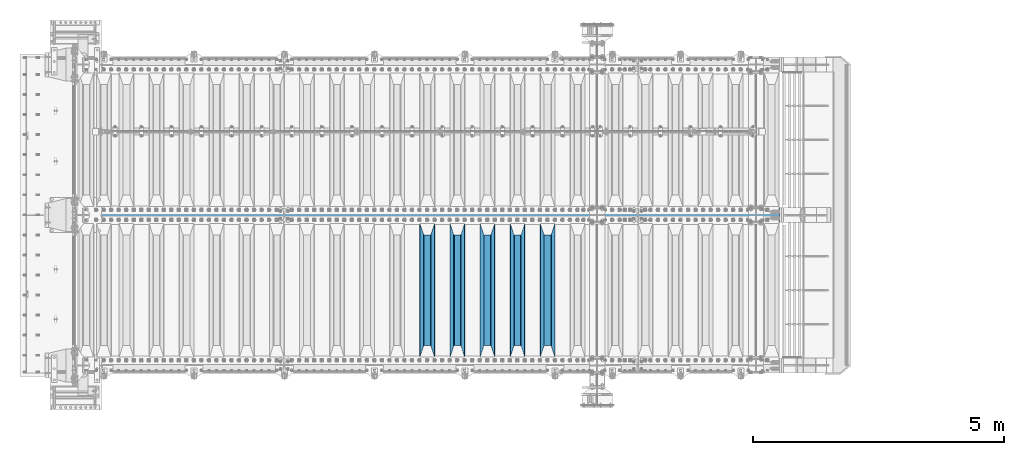
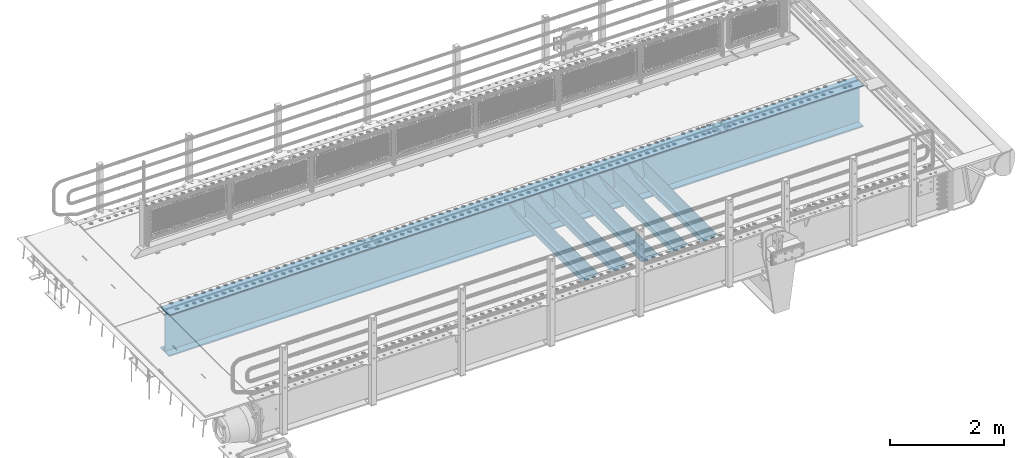
# One storey, part 94 of 193: 6 beams.
"""IFC2X3 building model written with IfcOpenShell, lengths in millimetres."""

from ifc_helpers import new_model, si_unit, frame, origin_with_axes, place, context, subcontext, project, spatial, faceted_brep, material, type_object, element, save


model = new_model("IFC2X3")

# Units and contexts
model_context = context("Model", 3, precision=1e-05, world=origin_with_axes())
body_context = subcontext(model_context, "Body", "Model", "MODEL_VIEW")
ifc_project = project(units=[si_unit("LENGTHUNIT", "METRE", prefix="MILLI"), si_unit("AREAUNIT", "SQUARE_METRE"), si_unit("VOLUMEUNIT", "CUBIC_METRE"), si_unit("MASSUNIT", "GRAM", prefix="KILO"), si_unit("TIMEUNIT", "SECOND"), si_unit("PLANEANGLEUNIT", "RADIAN"), si_unit("SOLIDANGLEUNIT", "STERADIAN"), si_unit("THERMODYNAMICTEMPERATUREUNIT", "DEGREE_CELSIUS"), si_unit("LUMINOUSINTENSITYUNIT", "LUMEN")], contexts=[model_context])

# Site, building, storey
site_placement = place(None, origin_with_axes())
site = spatial("IfcSite", under=ifc_project, at=site_placement, CompositionType="ELEMENT")
building_placement = place(site_placement, origin_with_axes())
building = spatial("IfcBuilding", under=site, at=building_placement, Name="Standard", CompositionType="ELEMENT")
storey_placement = place(building_placement, origin_with_axes())
storey = spatial("IfcBuildingStorey", under=building, at=storey_placement, Name="Undefined", CompositionType="ELEMENT", Elevation=0.0)

# Beams
ifc_material = material(Name="STEEL/S355N")
beam_type_1 = type_object("IfcBeamType", PredefinedType="NOTDEFINED")
beam_1_placement = place(storey_placement, frame((-33050.0, 24175.0, -115.0), z_axis=(0.0, 0.0, 1.0), x_axis=(0.0, 1.0, 0.0)))
element("IfcBeam", 1, at=beam_1_placement, inside=storey, type_object=beam_type_1, material=ifc_material, context=body_context, shape_type="Brep", body=[
    faceted_brep([(0.0, 150.0, 115.0), (0.0, 143.689999999999, 115.0), (2650.00000000297, 143.689999999999, 115.0), (2650.00000000297, 150.0, 115.0), (2650.00000000297, 142.059565218398, 110.000000003094), (2650.00000000297, 148.3695652184, 110.000000003094), (2441.90079219209, -80.1103600731112, -98.0992078077845), (2437.7588105432, -77.5672621345584, -102.241189456673), (2434.06523489747, -74.4080125315522, -105.934765102404), (2430.9108609509, -70.710272125576, -109.089139048974), (2428.37322971128, -66.5649389910068, -111.626770288588), (2426.51472138055, -62.0739139532889, -113.485278619323), (2425.38102192092, -57.3475956567672, -114.618978078955), (2424.99999999988, -52.5021667386536, -115.0), (2424.99999999988, 52.5021667386536, -115.0), (2425.38102192092, 57.3475956567672, -114.618978078955), (2426.51472138055, 62.0739139532889, -113.485278619323), (2428.37322971128, 66.5649389910068, -111.626770288588), (2430.9108609509, 70.710272125576, -109.089139048974), (2434.06523489747, 74.4080125315522, -105.934765102404), (2437.7588105432, 77.5672621345584, -102.241189456673), (2441.90079219209, 80.1103600731112, -98.0992078077846), (2446.38936140512, 81.9747917625791, -93.6106385947584), (2448.2494850041, 76.2713538057251, -91.7505149957729), (2444.62967112263, 74.76777986261, -95.3703288772456), (2441.28936334127, 72.7168944282894, -98.710636658607), (2438.31067330439, 70.1691124903846, -101.689326695487), (2435.76682334748, 67.1870637758839, -104.233176652398), (2433.72034654134, 63.8440531834895, -106.279653458539), (2432.22154950042, 60.222258798236, -107.778450499454), (2431.30727574265, 56.4107117849089, -108.692724257221), (2430.99999999987, 52.5031078186876, -109.0), (2430.99999999987, -52.5031078186876, -109.0), (2431.30727574265, -56.4107117849089, -108.692724257221), (2432.22154950042, -60.222258798236, -107.778450499454), (2433.72034654134, -63.8440531834895, -106.279653458539), (2435.76682334748, -67.1870637758839, -104.233176652398), (2438.31067330439, -70.1691124903846, -101.689326695487), (2441.28936334127, -72.7168944282894, -98.7106366586071), (2444.62967112263, -74.76777986261, -95.3703288772457), (2448.2494850041, -76.2713538057251, -91.7505149957729), (2650.00000000297, -142.059565218398, 110.000000003094), (2650.00000000297, -148.3695652184, 110.000000003094), (2446.38936140512, -81.9747917625791, -93.6106385947584), (2650.00000000297, -143.689999999999, 115.0), (2650.00000000297, -150.0, 115.0), (0.0, -143.689999999999, 115.0), (0.0, -150.0, 115.0), (0.0, -148.369565218261, 110.000000002667), (203.610638597427, -81.9747917625791, -93.6106385947584), (208.099207810446, -80.1103600731112, -98.0992078077845), (212.241189459342, -77.5672621345584, -102.241189456673), (215.93476510507, -74.4080125315522, -105.934765102404), (219.089139051641, -70.710272125576, -109.089139048974), (221.626770291256, -66.5649389910068, -111.626770288588), (223.485278621989, -62.0739139532889, -113.485278619323), (224.618978081624, -57.3475956567672, -114.618978078955), (225.000000002663, -52.5021667386536, -115.0), (225.000000002663, 52.5021667386536, -115.0), (224.618978081624, 57.3475956567672, -114.618978078955), (223.485278621989, 62.0739139532889, -113.485278619323), (221.626770291256, 66.5649389910068, -111.626770288588), (219.089139051641, 70.710272125576, -109.089139048974), (215.93476510507, 74.4080125315522, -105.934765102404), (212.241189459342, 77.5672621345584, -102.241189456673), (208.099207810446, 80.1103600731112, -98.0992078077846), (203.610638597427, 81.9747917625791, -93.6106385947584), (0.0, 148.369565218261, 110.000000002667), (0.0, 142.05956521826, 110.000000002667), (201.750514998439, 76.2713538057251, -91.7505149957729), (205.370328879915, 74.76777986261, -95.3703288772456), (208.710636661275, 72.7168944282894, -98.710636658607), (211.689326698157, 70.1691124903846, -101.689326695487), (214.233176655063, 67.1870637758839, -104.233176652398), (216.279653461206, 63.8440531834895, -106.279653458539), (217.778450502123, 60.222258798236, -107.778450499454), (218.69272425989, 56.4107117849089, -108.692724257221), (219.00000000267, 52.5031078186876, -109.0), (219.00000000267, -52.5031078186876, -109.0), (218.69272425989, -56.4107117849089, -108.692724257221), (217.778450502123, -60.222258798236, -107.778450499454), (216.279653461206, -63.8440531834895, -106.279653458539), (214.233176655063, -67.1870637758839, -104.233176652398), (211.689326698157, -70.1691124903846, -101.689326695487), (208.710636661275, -72.7168944282894, -98.7106366586071), (205.370328879915, -74.76777986261, -95.3703288772457), (201.750514998439, -76.2713538057251, -91.7505149957729), (0.0, -142.05956521826, 110.000000002667)], [[[0, 1, 2, 3]], [[3, 2, 4, 5]], [[6, 7, 8, 9, 10, 11, 12, 13, 14, 15, 16, 17, 18, 19, 20, 21, 22, 5, 4, 23, 24, 25, 26, 27, 28, 29, 30, 31, 32, 33, 34, 35, 36, 37, 38, 39, 40, 41, 42, 43]], [[44, 45, 42, 41]], [[46, 47, 45, 44]], [[43, 42, 45, 47, 48, 49]], [[6, 43, 49, 50]], [[7, 6, 50, 51]], [[8, 7, 51, 52]], [[9, 8, 52, 53]], [[10, 9, 53, 54]], [[11, 10, 54, 55]], [[12, 11, 55, 56]], [[13, 12, 56, 57]], [[14, 13, 57, 58]], [[15, 14, 58, 59]], [[16, 15, 59, 60]], [[17, 16, 60, 61]], [[18, 17, 61, 62]], [[19, 18, 62, 63]], [[20, 19, 63, 64]], [[21, 20, 64, 65]], [[22, 21, 65, 66]], [[0, 3, 5, 22, 66, 67]], [[1, 0, 67, 68]], [[23, 4, 2, 1, 68, 69]], [[24, 23, 69, 70]], [[25, 24, 70, 71]], [[26, 25, 71, 72]], [[27, 26, 72, 73]], [[28, 27, 73, 74]], [[29, 28, 74, 75]], [[30, 29, 75, 76]], [[31, 30, 76, 77]], [[32, 31, 77, 78]], [[33, 32, 78, 79]], [[34, 33, 79, 80]], [[35, 34, 80, 81]], [[36, 35, 81, 82]], [[37, 36, 82, 83]], [[38, 37, 83, 84]], [[39, 38, 84, 85]], [[40, 39, 85, 86]], [[46, 44, 41, 40, 86, 87]], [[47, 46, 87, 48]], [[86, 85, 84, 83, 82, 81, 80, 79, 78, 77, 76, 75, 74, 73, 72, 71, 70, 69, 68, 67, 66, 65, 64, 63, 62, 61, 60, 59, 58, 57, 56, 55, 54, 53, 52, 51, 50, 49, 48, 87]]]),
])
beam_2_placement = place(storey_placement, frame((-33650.0, 24175.0, -115.0), z_axis=(0.0, 0.0, 1.0), x_axis=(0.0, 1.0, 0.0)))
element("IfcBeam", 2, at=beam_2_placement, inside=storey, type_object=beam_type_1, material=ifc_material, context=body_context, shape_type="Brep", body=[
    faceted_brep([(0.0, 150.0, 115.0), (0.0, 143.689999999999, 115.0), (2650.00000000297, 143.689999999999, 115.0), (2650.00000000297, 150.0, 115.0), (2650.00000000297, 142.059565218398, 110.000000003094), (2650.00000000297, 148.3695652184, 110.000000003094), (2441.90079219209, -80.1103600731112, -98.0992078077845), (2437.7588105432, -77.5672621345584, -102.241189456673), (2434.06523489747, -74.4080125315522, -105.934765102404), (2430.9108609509, -70.710272125576, -109.089139048974), (2428.37322971128, -66.5649389910068, -111.626770288588), (2426.51472138055, -62.0739139532889, -113.485278619323), (2425.38102192092, -57.3475956567672, -114.618978078955), (2424.99999999988, -52.5021667386536, -115.0), (2424.99999999988, 52.5021667386536, -115.0), (2425.38102192092, 57.3475956567672, -114.618978078955), (2426.51472138055, 62.0739139532889, -113.485278619323), (2428.37322971128, 66.5649389910068, -111.626770288588), (2430.9108609509, 70.710272125576, -109.089139048974), (2434.06523489747, 74.4080125315522, -105.934765102404), (2437.7588105432, 77.5672621345584, -102.241189456673), (2441.90079219209, 80.1103600731112, -98.0992078077846), (2446.38936140512, 81.9747917625791, -93.6106385947584), (2448.2494850041, 76.2713538057251, -91.7505149957729), (2444.62967112263, 74.76777986261, -95.3703288772456), (2441.28936334127, 72.7168944282894, -98.710636658607), (2438.31067330439, 70.1691124903846, -101.689326695487), (2435.76682334748, 67.1870637758839, -104.233176652398), (2433.72034654134, 63.8440531834895, -106.279653458539), (2432.22154950042, 60.222258798236, -107.778450499454), (2431.30727574265, 56.4107117849089, -108.692724257221), (2430.99999999987, 52.5031078186876, -109.0), (2430.99999999987, -52.5031078186876, -109.0), (2431.30727574265, -56.4107117849089, -108.692724257221), (2432.22154950042, -60.222258798236, -107.778450499454), (2433.72034654134, -63.8440531834895, -106.279653458539), (2435.76682334748, -67.1870637758839, -104.233176652398), (2438.31067330439, -70.1691124903846, -101.689326695487), (2441.28936334127, -72.7168944282894, -98.7106366586071), (2444.62967112263, -74.76777986261, -95.3703288772457), (2448.2494850041, -76.2713538057251, -91.7505149957729), (2650.00000000297, -142.059565218398, 110.000000003094), (2650.00000000297, -148.3695652184, 110.000000003094), (2446.38936140512, -81.9747917625791, -93.6106385947584), (2650.00000000297, -143.689999999999, 115.0), (2650.00000000297, -150.0, 115.0), (0.0, -143.689999999999, 115.0), (0.0, -150.0, 115.0), (0.0, -148.369565218261, 110.000000002667), (203.610638597427, -81.9747917625791, -93.6106385947584), (208.099207810446, -80.1103600731112, -98.0992078077845), (212.241189459342, -77.5672621345584, -102.241189456673), (215.93476510507, -74.4080125315522, -105.934765102404), (219.089139051641, -70.710272125576, -109.089139048974), (221.626770291256, -66.5649389910068, -111.626770288588), (223.485278621989, -62.0739139532889, -113.485278619323), (224.618978081624, -57.3475956567672, -114.618978078955), (225.000000002663, -52.5021667386536, -115.0), (225.000000002663, 52.5021667386536, -115.0), (224.618978081624, 57.3475956567672, -114.618978078955), (223.485278621989, 62.0739139532889, -113.485278619323), (221.626770291256, 66.5649389910068, -111.626770288588), (219.089139051641, 70.710272125576, -109.089139048974), (215.93476510507, 74.4080125315522, -105.934765102404), (212.241189459342, 77.5672621345584, -102.241189456673), (208.099207810446, 80.1103600731112, -98.0992078077846), (203.610638597427, 81.9747917625791, -93.6106385947584), (0.0, 148.369565218261, 110.000000002667), (0.0, 142.05956521826, 110.000000002667), (201.750514998439, 76.2713538057251, -91.7505149957729), (205.370328879915, 74.76777986261, -95.3703288772456), (208.710636661275, 72.7168944282894, -98.710636658607), (211.689326698157, 70.1691124903846, -101.689326695487), (214.233176655063, 67.1870637758839, -104.233176652398), (216.279653461206, 63.8440531834895, -106.279653458539), (217.778450502123, 60.222258798236, -107.778450499454), (218.69272425989, 56.4107117849089, -108.692724257221), (219.00000000267, 52.5031078186876, -109.0), (219.00000000267, -52.5031078186876, -109.0), (218.69272425989, -56.4107117849089, -108.692724257221), (217.778450502123, -60.222258798236, -107.778450499454), (216.279653461206, -63.8440531834895, -106.279653458539), (214.233176655063, -67.1870637758839, -104.233176652398), (211.689326698157, -70.1691124903846, -101.689326695487), (208.710636661275, -72.7168944282894, -98.7106366586071), (205.370328879915, -74.76777986261, -95.3703288772457), (201.750514998439, -76.2713538057251, -91.7505149957729), (0.0, -142.05956521826, 110.000000002667)], [[[0, 1, 2, 3]], [[3, 2, 4, 5]], [[6, 7, 8, 9, 10, 11, 12, 13, 14, 15, 16, 17, 18, 19, 20, 21, 22, 5, 4, 23, 24, 25, 26, 27, 28, 29, 30, 31, 32, 33, 34, 35, 36, 37, 38, 39, 40, 41, 42, 43]], [[44, 45, 42, 41]], [[46, 47, 45, 44]], [[43, 42, 45, 47, 48, 49]], [[6, 43, 49, 50]], [[7, 6, 50, 51]], [[8, 7, 51, 52]], [[9, 8, 52, 53]], [[10, 9, 53, 54]], [[11, 10, 54, 55]], [[12, 11, 55, 56]], [[13, 12, 56, 57]], [[14, 13, 57, 58]], [[15, 14, 58, 59]], [[16, 15, 59, 60]], [[17, 16, 60, 61]], [[18, 17, 61, 62]], [[19, 18, 62, 63]], [[20, 19, 63, 64]], [[21, 20, 64, 65]], [[22, 21, 65, 66]], [[0, 3, 5, 22, 66, 67]], [[1, 0, 67, 68]], [[23, 4, 2, 1, 68, 69]], [[24, 23, 69, 70]], [[25, 24, 70, 71]], [[26, 25, 71, 72]], [[27, 26, 72, 73]], [[28, 27, 73, 74]], [[29, 28, 74, 75]], [[30, 29, 75, 76]], [[31, 30, 76, 77]], [[32, 31, 77, 78]], [[33, 32, 78, 79]], [[34, 33, 79, 80]], [[35, 34, 80, 81]], [[36, 35, 81, 82]], [[37, 36, 82, 83]], [[38, 37, 83, 84]], [[39, 38, 84, 85]], [[40, 39, 85, 86]], [[46, 44, 41, 40, 86, 87]], [[47, 46, 87, 48]], [[86, 85, 84, 83, 82, 81, 80, 79, 78, 77, 76, 75, 74, 73, 72, 71, 70, 69, 68, 67, 66, 65, 64, 63, 62, 61, 60, 59, 58, 57, 56, 55, 54, 53, 52, 51, 50, 49, 48, 87]]]),
])
beam_3_placement = place(storey_placement, frame((-34250.0, 24175.0, -115.0), z_axis=(0.0, 0.0, 1.0), x_axis=(0.0, 1.0, 0.0)))
element("IfcBeam", 3, at=beam_3_placement, inside=storey, type_object=beam_type_1, material=ifc_material, context=body_context, shape_type="Brep", body=[
    faceted_brep([(0.0, 150.0, 115.0), (0.0, 143.689999999999, 115.0), (2650.00000000297, 143.689999999999, 115.0), (2650.00000000297, 150.0, 115.0), (2650.00000000297, 142.059565218398, 110.000000003094), (2650.00000000297, 148.3695652184, 110.000000003094), (2441.90079219209, -80.1103600731112, -98.0992078077845), (2437.7588105432, -77.5672621345584, -102.241189456673), (2434.06523489747, -74.4080125315522, -105.934765102404), (2430.9108609509, -70.710272125576, -109.089139048974), (2428.37322971128, -66.5649389910068, -111.626770288588), (2426.51472138055, -62.0739139532889, -113.485278619323), (2425.38102192092, -57.3475956567672, -114.618978078955), (2424.99999999988, -52.5021667386536, -115.0), (2424.99999999988, 52.5021667386536, -115.0), (2425.38102192092, 57.3475956567672, -114.618978078955), (2426.51472138055, 62.0739139532889, -113.485278619323), (2428.37322971128, 66.5649389910068, -111.626770288588), (2430.9108609509, 70.710272125576, -109.089139048974), (2434.06523489747, 74.4080125315522, -105.934765102404), (2437.7588105432, 77.5672621345584, -102.241189456673), (2441.90079219209, 80.1103600731112, -98.0992078077846), (2446.38936140512, 81.9747917625791, -93.6106385947584), (2448.2494850041, 76.2713538057251, -91.7505149957729), (2444.62967112263, 74.76777986261, -95.3703288772456), (2441.28936334127, 72.7168944282894, -98.710636658607), (2438.31067330439, 70.1691124903846, -101.689326695487), (2435.76682334748, 67.1870637758839, -104.233176652398), (2433.72034654134, 63.8440531834895, -106.279653458539), (2432.22154950042, 60.222258798236, -107.778450499454), (2431.30727574265, 56.4107117849089, -108.692724257221), (2430.99999999987, 52.5031078186876, -109.0), (2430.99999999987, -52.5031078186876, -109.0), (2431.30727574265, -56.4107117849089, -108.692724257221), (2432.22154950042, -60.222258798236, -107.778450499454), (2433.72034654134, -63.8440531834895, -106.279653458539), (2435.76682334748, -67.1870637758839, -104.233176652398), (2438.31067330439, -70.1691124903846, -101.689326695487), (2441.28936334127, -72.7168944282894, -98.7106366586071), (2444.62967112263, -74.76777986261, -95.3703288772457), (2448.2494850041, -76.2713538057251, -91.7505149957729), (2650.00000000297, -142.059565218398, 110.000000003094), (2650.00000000297, -148.3695652184, 110.000000003094), (2446.38936140512, -81.9747917625791, -93.6106385947584), (2650.00000000297, -143.689999999999, 115.0), (2650.00000000297, -150.0, 115.0), (0.0, -143.689999999999, 115.0), (0.0, -150.0, 115.0), (0.0, -148.369565218261, 110.000000002667), (203.610638597427, -81.9747917625791, -93.6106385947584), (208.099207810446, -80.1103600731112, -98.0992078077845), (212.241189459342, -77.5672621345584, -102.241189456673), (215.93476510507, -74.4080125315522, -105.934765102404), (219.089139051641, -70.710272125576, -109.089139048974), (221.626770291256, -66.5649389910068, -111.626770288588), (223.485278621989, -62.0739139532889, -113.485278619323), (224.618978081624, -57.3475956567672, -114.618978078955), (225.000000002663, -52.5021667386536, -115.0), (225.000000002663, 52.5021667386536, -115.0), (224.618978081624, 57.3475956567672, -114.618978078955), (223.485278621989, 62.0739139532889, -113.485278619323), (221.626770291256, 66.5649389910068, -111.626770288588), (219.089139051641, 70.710272125576, -109.089139048974), (215.93476510507, 74.4080125315522, -105.934765102404), (212.241189459342, 77.5672621345584, -102.241189456673), (208.099207810446, 80.1103600731112, -98.0992078077846), (203.610638597427, 81.9747917625791, -93.6106385947584), (0.0, 148.369565218261, 110.000000002667), (0.0, 142.05956521826, 110.000000002667), (201.750514998439, 76.2713538057251, -91.7505149957729), (205.370328879915, 74.76777986261, -95.3703288772456), (208.710636661275, 72.7168944282894, -98.710636658607), (211.689326698157, 70.1691124903846, -101.689326695487), (214.233176655063, 67.1870637758839, -104.233176652398), (216.279653461206, 63.8440531834895, -106.279653458539), (217.778450502123, 60.222258798236, -107.778450499454), (218.69272425989, 56.4107117849089, -108.692724257221), (219.00000000267, 52.5031078186876, -109.0), (219.00000000267, -52.5031078186876, -109.0), (218.69272425989, -56.4107117849089, -108.692724257221), (217.778450502123, -60.222258798236, -107.778450499454), (216.279653461206, -63.8440531834895, -106.279653458539), (214.233176655063, -67.1870637758839, -104.233176652398), (211.689326698157, -70.1691124903846, -101.689326695487), (208.710636661275, -72.7168944282894, -98.7106366586071), (205.370328879915, -74.76777986261, -95.3703288772457), (201.750514998439, -76.2713538057251, -91.7505149957729), (0.0, -142.05956521826, 110.000000002667)], [[[0, 1, 2, 3]], [[3, 2, 4, 5]], [[6, 7, 8, 9, 10, 11, 12, 13, 14, 15, 16, 17, 18, 19, 20, 21, 22, 5, 4, 23, 24, 25, 26, 27, 28, 29, 30, 31, 32, 33, 34, 35, 36, 37, 38, 39, 40, 41, 42, 43]], [[44, 45, 42, 41]], [[46, 47, 45, 44]], [[43, 42, 45, 47, 48, 49]], [[6, 43, 49, 50]], [[7, 6, 50, 51]], [[8, 7, 51, 52]], [[9, 8, 52, 53]], [[10, 9, 53, 54]], [[11, 10, 54, 55]], [[12, 11, 55, 56]], [[13, 12, 56, 57]], [[14, 13, 57, 58]], [[15, 14, 58, 59]], [[16, 15, 59, 60]], [[17, 16, 60, 61]], [[18, 17, 61, 62]], [[19, 18, 62, 63]], [[20, 19, 63, 64]], [[21, 20, 64, 65]], [[22, 21, 65, 66]], [[0, 3, 5, 22, 66, 67]], [[1, 0, 67, 68]], [[23, 4, 2, 1, 68, 69]], [[24, 23, 69, 70]], [[25, 24, 70, 71]], [[26, 25, 71, 72]], [[27, 26, 72, 73]], [[28, 27, 73, 74]], [[29, 28, 74, 75]], [[30, 29, 75, 76]], [[31, 30, 76, 77]], [[32, 31, 77, 78]], [[33, 32, 78, 79]], [[34, 33, 79, 80]], [[35, 34, 80, 81]], [[36, 35, 81, 82]], [[37, 36, 82, 83]], [[38, 37, 83, 84]], [[39, 38, 84, 85]], [[40, 39, 85, 86]], [[46, 44, 41, 40, 86, 87]], [[47, 46, 87, 48]], [[86, 85, 84, 83, 82, 81, 80, 79, 78, 77, 76, 75, 74, 73, 72, 71, 70, 69, 68, 67, 66, 65, 64, 63, 62, 61, 60, 59, 58, 57, 56, 55, 54, 53, 52, 51, 50, 49, 48, 87]]]),
])
beam_4_placement = place(storey_placement, frame((-34850.0, 24175.0, -115.0), z_axis=(0.0, 0.0, 1.0), x_axis=(0.0, 1.0, 0.0)))
element("IfcBeam", 4, at=beam_4_placement, inside=storey, type_object=beam_type_1, material=ifc_material, context=body_context, shape_type="Brep", body=[
    faceted_brep([(0.0, 150.0, 115.0), (0.0, 143.689999999999, 115.0), (2650.00000000297, 143.689999999999, 115.0), (2650.00000000297, 150.0, 115.0), (2650.00000000297, 142.059565218398, 110.000000003094), (2650.00000000297, 148.3695652184, 110.000000003094), (2441.90079219209, -80.1103600731112, -98.0992078077845), (2437.7588105432, -77.5672621345584, -102.241189456673), (2434.06523489747, -74.4080125315522, -105.934765102404), (2430.9108609509, -70.710272125576, -109.089139048974), (2428.37322971128, -66.5649389910068, -111.626770288588), (2426.51472138055, -62.0739139532889, -113.485278619323), (2425.38102192092, -57.3475956567672, -114.618978078955), (2424.99999999988, -52.5021667386536, -115.0), (2424.99999999988, 52.5021667386536, -115.0), (2425.38102192092, 57.3475956567672, -114.618978078955), (2426.51472138055, 62.0739139532889, -113.485278619323), (2428.37322971128, 66.5649389910068, -111.626770288588), (2430.9108609509, 70.710272125576, -109.089139048974), (2434.06523489747, 74.4080125315522, -105.934765102404), (2437.7588105432, 77.5672621345584, -102.241189456673), (2441.90079219209, 80.1103600731112, -98.0992078077846), (2446.38936140512, 81.9747917625791, -93.6106385947584), (2448.2494850041, 76.2713538057251, -91.7505149957729), (2444.62967112263, 74.76777986261, -95.3703288772456), (2441.28936334127, 72.7168944282894, -98.710636658607), (2438.31067330439, 70.1691124903846, -101.689326695487), (2435.76682334748, 67.1870637758839, -104.233176652398), (2433.72034654134, 63.8440531834895, -106.279653458539), (2432.22154950042, 60.222258798236, -107.778450499454), (2431.30727574265, 56.4107117849089, -108.692724257221), (2430.99999999987, 52.5031078186876, -109.0), (2430.99999999987, -52.5031078186876, -109.0), (2431.30727574265, -56.4107117849089, -108.692724257221), (2432.22154950042, -60.222258798236, -107.778450499454), (2433.72034654134, -63.8440531834895, -106.279653458539), (2435.76682334748, -67.1870637758839, -104.233176652398), (2438.31067330439, -70.1691124903846, -101.689326695487), (2441.28936334127, -72.7168944282894, -98.7106366586071), (2444.62967112263, -74.76777986261, -95.3703288772457), (2448.2494850041, -76.2713538057251, -91.7505149957729), (2650.00000000297, -142.059565218398, 110.000000003094), (2650.00000000297, -148.3695652184, 110.000000003094), (2446.38936140512, -81.9747917625791, -93.6106385947584), (2650.00000000297, -143.689999999999, 115.0), (2650.00000000297, -150.0, 115.0), (0.0, -143.689999999999, 115.0), (0.0, -150.0, 115.0), (0.0, -148.369565218261, 110.000000002667), (203.610638597427, -81.9747917625791, -93.6106385947584), (208.099207810446, -80.1103600731112, -98.0992078077845), (212.241189459342, -77.5672621345584, -102.241189456673), (215.93476510507, -74.4080125315522, -105.934765102404), (219.089139051641, -70.710272125576, -109.089139048974), (221.626770291256, -66.5649389910068, -111.626770288588), (223.485278621989, -62.0739139532889, -113.485278619323), (224.618978081624, -57.3475956567672, -114.618978078955), (225.000000002663, -52.5021667386536, -115.0), (225.000000002663, 52.5021667386536, -115.0), (224.618978081624, 57.3475956567672, -114.618978078955), (223.485278621989, 62.0739139532889, -113.485278619323), (221.626770291256, 66.5649389910068, -111.626770288588), (219.089139051641, 70.710272125576, -109.089139048974), (215.93476510507, 74.4080125315522, -105.934765102404), (212.241189459342, 77.5672621345584, -102.241189456673), (208.099207810446, 80.1103600731112, -98.0992078077846), (203.610638597427, 81.9747917625791, -93.6106385947584), (0.0, 148.369565218261, 110.000000002667), (0.0, 142.05956521826, 110.000000002667), (201.750514998439, 76.2713538057251, -91.7505149957729), (205.370328879915, 74.76777986261, -95.3703288772456), (208.710636661275, 72.7168944282894, -98.710636658607), (211.689326698157, 70.1691124903846, -101.689326695487), (214.233176655063, 67.1870637758839, -104.233176652398), (216.279653461206, 63.8440531834895, -106.279653458539), (217.778450502123, 60.222258798236, -107.778450499454), (218.69272425989, 56.4107117849089, -108.692724257221), (219.00000000267, 52.5031078186876, -109.0), (219.00000000267, -52.5031078186876, -109.0), (218.69272425989, -56.4107117849089, -108.692724257221), (217.778450502123, -60.222258798236, -107.778450499454), (216.279653461206, -63.8440531834895, -106.279653458539), (214.233176655063, -67.1870637758839, -104.233176652398), (211.689326698157, -70.1691124903846, -101.689326695487), (208.710636661275, -72.7168944282894, -98.7106366586071), (205.370328879915, -74.76777986261, -95.3703288772457), (201.750514998439, -76.2713538057251, -91.7505149957729), (0.0, -142.05956521826, 110.000000002667)], [[[0, 1, 2, 3]], [[3, 2, 4, 5]], [[6, 7, 8, 9, 10, 11, 12, 13, 14, 15, 16, 17, 18, 19, 20, 21, 22, 5, 4, 23, 24, 25, 26, 27, 28, 29, 30, 31, 32, 33, 34, 35, 36, 37, 38, 39, 40, 41, 42, 43]], [[44, 45, 42, 41]], [[46, 47, 45, 44]], [[43, 42, 45, 47, 48, 49]], [[6, 43, 49, 50]], [[7, 6, 50, 51]], [[8, 7, 51, 52]], [[9, 8, 52, 53]], [[10, 9, 53, 54]], [[11, 10, 54, 55]], [[12, 11, 55, 56]], [[13, 12, 56, 57]], [[14, 13, 57, 58]], [[15, 14, 58, 59]], [[16, 15, 59, 60]], [[17, 16, 60, 61]], [[18, 17, 61, 62]], [[19, 18, 62, 63]], [[20, 19, 63, 64]], [[21, 20, 64, 65]], [[22, 21, 65, 66]], [[0, 3, 5, 22, 66, 67]], [[1, 0, 67, 68]], [[23, 4, 2, 1, 68, 69]], [[24, 23, 69, 70]], [[25, 24, 70, 71]], [[26, 25, 71, 72]], [[27, 26, 72, 73]], [[28, 27, 73, 74]], [[29, 28, 74, 75]], [[30, 29, 75, 76]], [[31, 30, 76, 77]], [[32, 31, 77, 78]], [[33, 32, 78, 79]], [[34, 33, 79, 80]], [[35, 34, 80, 81]], [[36, 35, 81, 82]], [[37, 36, 82, 83]], [[38, 37, 83, 84]], [[39, 38, 84, 85]], [[40, 39, 85, 86]], [[46, 44, 41, 40, 86, 87]], [[47, 46, 87, 48]], [[86, 85, 84, 83, 82, 81, 80, 79, 78, 77, 76, 75, 74, 73, 72, 71, 70, 69, 68, 67, 66, 65, 64, 63, 62, 61, 60, 59, 58, 57, 56, 55, 54, 53, 52, 51, 50, 49, 48, 87]]]),
])
beam_5_placement = place(storey_placement, frame((-35450.0, 24175.0, -115.0), z_axis=(0.0, 0.0, 1.0), x_axis=(0.0, 1.0, 0.0)))
element("IfcBeam", 5, at=beam_5_placement, inside=storey, type_object=beam_type_1, material=ifc_material, context=body_context, shape_type="Brep", body=[
    faceted_brep([(0.0, 150.0, 115.0), (0.0, 143.689999999999, 115.0), (2650.00000000297, 143.689999999999, 115.0), (2650.00000000297, 150.0, 115.0), (2650.00000000297, 142.059565218398, 110.000000003094), (2650.00000000297, 148.3695652184, 110.000000003094), (2441.90079219209, -80.1103600731112, -98.0992078077845), (2437.7588105432, -77.5672621345584, -102.241189456673), (2434.06523489747, -74.4080125315522, -105.934765102404), (2430.9108609509, -70.710272125576, -109.089139048974), (2428.37322971128, -66.5649389910068, -111.626770288588), (2426.51472138055, -62.0739139532889, -113.485278619323), (2425.38102192092, -57.3475956567672, -114.618978078955), (2424.99999999988, -52.5021667386536, -115.0), (2424.99999999988, 52.5021667386536, -115.0), (2425.38102192092, 57.3475956567672, -114.618978078955), (2426.51472138055, 62.0739139532889, -113.485278619323), (2428.37322971128, 66.5649389910068, -111.626770288588), (2430.9108609509, 70.710272125576, -109.089139048974), (2434.06523489747, 74.4080125315522, -105.934765102404), (2437.7588105432, 77.5672621345584, -102.241189456673), (2441.90079219209, 80.1103600731112, -98.0992078077846), (2446.38936140512, 81.9747917625791, -93.6106385947584), (2448.2494850041, 76.2713538057251, -91.7505149957729), (2444.62967112263, 74.76777986261, -95.3703288772456), (2441.28936334127, 72.7168944282894, -98.710636658607), (2438.31067330439, 70.1691124903846, -101.689326695487), (2435.76682334748, 67.1870637758839, -104.233176652398), (2433.72034654134, 63.8440531834895, -106.279653458539), (2432.22154950042, 60.222258798236, -107.778450499454), (2431.30727574265, 56.4107117849089, -108.692724257221), (2430.99999999987, 52.5031078186876, -109.0), (2430.99999999987, -52.5031078186876, -109.0), (2431.30727574265, -56.4107117849089, -108.692724257221), (2432.22154950042, -60.222258798236, -107.778450499454), (2433.72034654134, -63.8440531834895, -106.279653458539), (2435.76682334748, -67.1870637758839, -104.233176652398), (2438.31067330439, -70.1691124903846, -101.689326695487), (2441.28936334127, -72.7168944282894, -98.7106366586071), (2444.62967112263, -74.76777986261, -95.3703288772457), (2448.2494850041, -76.2713538057251, -91.7505149957729), (2650.00000000297, -142.059565218398, 110.000000003094), (2650.00000000297, -148.3695652184, 110.000000003094), (2446.38936140512, -81.9747917625791, -93.6106385947584), (2650.00000000297, -143.689999999999, 115.0), (2650.00000000297, -150.0, 115.0), (0.0, -143.689999999999, 115.0), (0.0, -150.0, 115.0), (0.0, -148.369565218261, 110.000000002667), (203.610638597427, -81.9747917625791, -93.6106385947584), (208.099207810446, -80.1103600731112, -98.0992078077845), (212.241189459342, -77.5672621345584, -102.241189456673), (215.93476510507, -74.4080125315522, -105.934765102404), (219.089139051641, -70.710272125576, -109.089139048974), (221.626770291256, -66.5649389910068, -111.626770288588), (223.485278621989, -62.0739139532889, -113.485278619323), (224.618978081624, -57.3475956567672, -114.618978078955), (225.000000002663, -52.5021667386536, -115.0), (225.000000002663, 52.5021667386536, -115.0), (224.618978081624, 57.3475956567672, -114.618978078955), (223.485278621989, 62.0739139532889, -113.485278619323), (221.626770291256, 66.5649389910068, -111.626770288588), (219.089139051641, 70.710272125576, -109.089139048974), (215.93476510507, 74.4080125315522, -105.934765102404), (212.241189459342, 77.5672621345584, -102.241189456673), (208.099207810446, 80.1103600731112, -98.0992078077846), (203.610638597427, 81.9747917625791, -93.6106385947584), (0.0, 148.369565218261, 110.000000002667), (0.0, 142.05956521826, 110.000000002667), (201.750514998439, 76.2713538057251, -91.7505149957729), (205.370328879915, 74.76777986261, -95.3703288772456), (208.710636661275, 72.7168944282894, -98.710636658607), (211.689326698157, 70.1691124903846, -101.689326695487), (214.233176655063, 67.1870637758839, -104.233176652398), (216.279653461206, 63.8440531834895, -106.279653458539), (217.778450502123, 60.222258798236, -107.778450499454), (218.69272425989, 56.4107117849089, -108.692724257221), (219.00000000267, 52.5031078186876, -109.0), (219.00000000267, -52.5031078186876, -109.0), (218.69272425989, -56.4107117849089, -108.692724257221), (217.778450502123, -60.222258798236, -107.778450499454), (216.279653461206, -63.8440531834895, -106.279653458539), (214.233176655063, -67.1870637758839, -104.233176652398), (211.689326698157, -70.1691124903846, -101.689326695487), (208.710636661275, -72.7168944282894, -98.7106366586071), (205.370328879915, -74.76777986261, -95.3703288772457), (201.750514998439, -76.2713538057251, -91.7505149957729), (0.0, -142.05956521826, 110.000000002667)], [[[0, 1, 2, 3]], [[3, 2, 4, 5]], [[6, 7, 8, 9, 10, 11, 12, 13, 14, 15, 16, 17, 18, 19, 20, 21, 22, 5, 4, 23, 24, 25, 26, 27, 28, 29, 30, 31, 32, 33, 34, 35, 36, 37, 38, 39, 40, 41, 42, 43]], [[44, 45, 42, 41]], [[46, 47, 45, 44]], [[43, 42, 45, 47, 48, 49]], [[6, 43, 49, 50]], [[7, 6, 50, 51]], [[8, 7, 51, 52]], [[9, 8, 52, 53]], [[10, 9, 53, 54]], [[11, 10, 54, 55]], [[12, 11, 55, 56]], [[13, 12, 56, 57]], [[14, 13, 57, 58]], [[15, 14, 58, 59]], [[16, 15, 59, 60]], [[17, 16, 60, 61]], [[18, 17, 61, 62]], [[19, 18, 62, 63]], [[20, 19, 63, 64]], [[21, 20, 64, 65]], [[22, 21, 65, 66]], [[0, 3, 5, 22, 66, 67]], [[1, 0, 67, 68]], [[23, 4, 2, 1, 68, 69]], [[24, 23, 69, 70]], [[25, 24, 70, 71]], [[26, 25, 71, 72]], [[27, 26, 72, 73]], [[28, 27, 73, 74]], [[29, 28, 74, 75]], [[30, 29, 75, 76]], [[31, 30, 76, 77]], [[32, 31, 77, 78]], [[33, 32, 78, 79]], [[34, 33, 79, 80]], [[35, 34, 80, 81]], [[36, 35, 81, 82]], [[37, 36, 82, 83]], [[38, 37, 83, 84]], [[39, 38, 84, 85]], [[40, 39, 85, 86]], [[46, 44, 41, 40, 86, 87]], [[47, 46, 87, 48]], [[86, 85, 84, 83, 82, 81, 80, 79, 78, 77, 76, 75, 74, 73, 72, 71, 70, 69, 68, 67, 66, 65, 64, 63, 62, 61, 60, 59, 58, 57, 56, 55, 54, 53, 52, 51, 50, 49, 48, 87]]]),
])
beam_type_2 = type_object("IfcBeamType", Name="HEA900", PredefinedType="NOTDEFINED")
beam_6_placement = place(storey_placement, frame((-42440.0, 27000.0, -445.0), z_axis=(0.0, 0.0, 1.0), x_axis=(1.0, 0.0, 0.0)))
element("IfcBeam", 6, at=beam_6_placement, inside=storey, type_object=beam_type_2, material=ifc_material, ObjectType="HEA900", context=body_context, shape_type="Brep", body=[
    faceted_brep([(0.0, 150.0, -445.0), (0.0, 150.0, -415.0), (14017.0, 150.0, -415.0), (14017.0, 150.0, -445.0), (0.0, 8.0, -415.0), (14017.0, 8.0, -415.0), (0.0, 8.0, 415.0), (14017.0, 8.0, 415.0), (0.0, 150.0, 415.0), (14017.0, 150.0, 415.0), (0.0, 150.0, 445.0), (14017.0, 150.0, 445.0), (0.0, -150.0, 445.0), (14017.0, -150.0, 445.0), (0.0, -150.0, 415.0), (14017.0, -150.0, 415.0), (0.0, -8.0, 415.0), (14017.0, -8.0, 415.0), (0.0, -8.0, -415.0), (14017.0, -8.0, -415.0), (0.0, -150.0, -415.0), (14017.0, -150.0, -415.0), (0.0, -150.0, -445.0), (14017.0, -150.0, -445.0)], [[[0, 1, 2, 3]], [[1, 4, 5, 2]], [[4, 6, 7, 5]], [[6, 8, 9, 7]], [[8, 10, 11, 9]], [[10, 12, 13, 11]], [[12, 14, 15, 13]], [[14, 16, 17, 15]], [[16, 18, 19, 17]], [[18, 20, 21, 19]], [[20, 22, 23, 21]], [[22, 0, 3, 23]], [[5, 7, 9, 11, 13, 15, 17, 19, 21, 23, 3, 2]], [[22, 20, 18, 16, 14, 12, 10, 8, 6, 4, 1, 0]]]),
])

save(model, "model.ifc")
